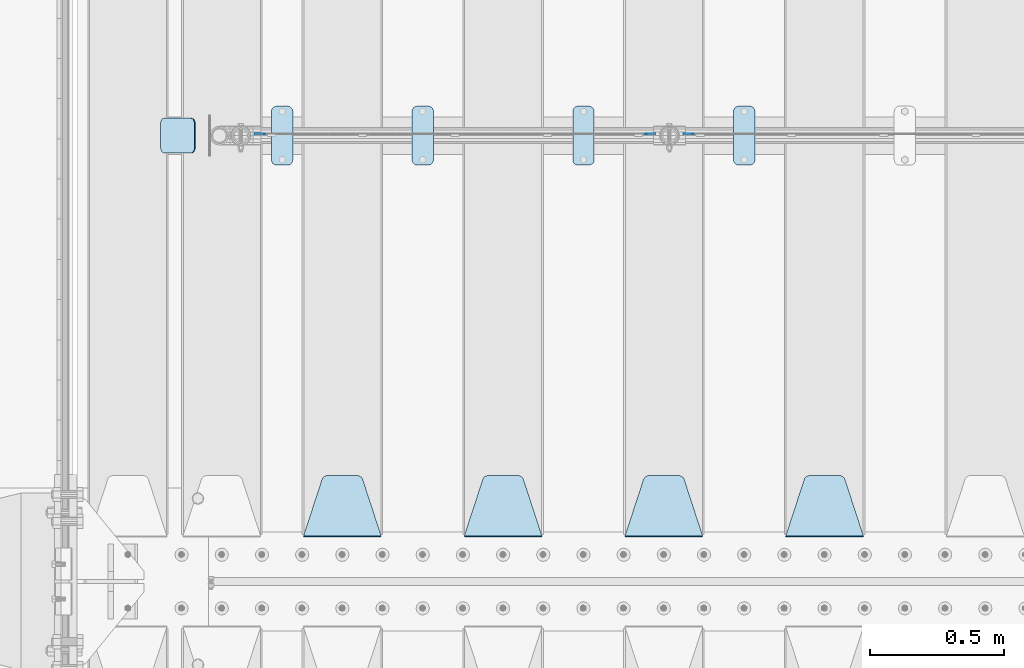
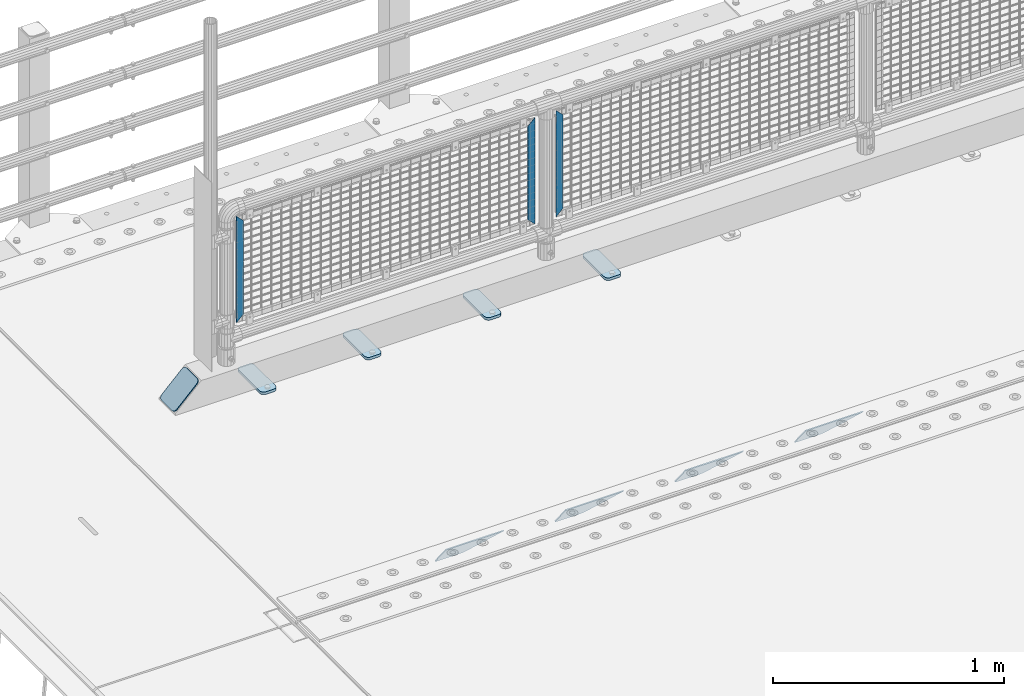
# One storey, part 170 of 208: 12 plates.
"""IFC2X3 building model written with IfcOpenShell, lengths in millimetres."""

from ifc_helpers import new_model, si_unit, frame, origin_with_axes, place, context, subcontext, project, spatial, faceted_brep, material, type_object, element, save


model = new_model("IFC2X3")

# Units and contexts
model_context = context("Model", 3, precision=1e-05, world=origin_with_axes())
body_context = subcontext(model_context, "Body", "Model", "MODEL_VIEW")
ifc_project = project(units=[si_unit("LENGTHUNIT", "METRE", prefix="MILLI"), si_unit("AREAUNIT", "SQUARE_METRE"), si_unit("VOLUMEUNIT", "CUBIC_METRE"), si_unit("MASSUNIT", "GRAM", prefix="KILO"), si_unit("TIMEUNIT", "SECOND"), si_unit("PLANEANGLEUNIT", "RADIAN"), si_unit("SOLIDANGLEUNIT", "STERADIAN"), si_unit("THERMODYNAMICTEMPERATUREUNIT", "DEGREE_CELSIUS"), si_unit("LUMINOUSINTENSITYUNIT", "LUMEN")], contexts=[model_context])

# Site, building, storey
site_placement = place(None, origin_with_axes())
site = spatial("IfcSite", under=ifc_project, at=site_placement, CompositionType="ELEMENT")
building_placement = place(site_placement, origin_with_axes())
building = spatial("IfcBuilding", under=site, at=building_placement, Name="Standard", CompositionType="ELEMENT")
storey_placement = place(building_placement, origin_with_axes())
storey = spatial("IfcBuildingStorey", under=building, at=storey_placement, Name="Undefined", CompositionType="ELEMENT", Elevation=0.0)

# Plates
ifc_material_1 = material(Name="STEEL/S355J2")
plate_type_1 = type_object("IfcPlateType", PredefinedType="NOTDEFINED")
plate_1_placement = place(storey_placement, frame((-39990.0, 4774.5, 21.0199999999977), z_axis=(1.0, 0.0, 0.0), x_axis=(0.0, -1.0, 0.0)))
element("IfcPlate", 1, at=plate_1_placement, inside=storey, type_object=plate_type_1, material=ifc_material_1, context=body_context, shape_type="Brep", body=[
    faceted_brep([(0.0, -7.0, 20.0), (0.0, -7.0, 60.0), (0.0, 7.0, 60.0), (0.0, 7.0, 20.0), (0.384294391935327, -7.0, 63.9018064403208), (0.384294391935327, 7.0, 63.9018064403208), (1.52240934977453, -7.0, 67.6536686473009), (1.52240934977453, 7.0, 67.6536686473009), (3.37060775394912, -7.0, 71.1114046603907), (3.37060775394912, 7.0, 71.1114046603907), (5.85786437626939, -7.0, 74.1421356237297), (5.85786437626939, 7.0, 74.1421356237297), (8.8885953396084, -7.0, 76.62939224605), (8.8885953396084, 7.0, 76.62939224605), (12.3463313526981, -7.0, 78.4775906502255), (12.3463313526981, 7.0, 78.4775906502255), (16.0981935596774, -7.0, 79.6157056080629), (16.0981935596774, 7.0, 79.6157056080629), (20.0, -7.0, 80.0), (20.0, 7.0, 80.0), (200.0, -7.0, 80.0), (200.0, 7.0, 80.0), (203.901806440323, -7.0, 79.6157056080629), (203.901806440323, 7.0, 79.6157056080629), (207.653668647302, -7.0, 78.4775906502255), (207.653668647302, 7.0, 78.4775906502255), (211.111404660393, -7.0, 76.62939224605), (211.111404660393, 7.0, 76.62939224605), (214.142135623731, -7.0, 74.1421356237297), (214.142135623731, 7.0, 74.1421356237297), (216.629392246051, -7.0, 71.1114046603907), (216.629392246051, 7.0, 71.1114046603907), (218.477590650225, -7.0, 67.6536686473009), (218.477590650225, 7.0, 67.6536686473009), (219.615705608065, -7.0, 63.9018064403208), (219.615705608065, 7.0, 63.9018064403208), (220.0, -7.0, 60.0), (220.0, 7.0, 60.0), (220.0, -7.0, 20.0), (220.0, 7.0, 20.0), (219.615705608065, -7.0, 16.0981935596792), (219.615705608065, 7.0, 16.0981935596792), (218.477590650225, -7.0, 12.3463313526991), (218.477590650225, 7.0, 12.3463313526991), (216.629392246051, -7.0, 8.88859533960931), (216.629392246051, 7.0, 8.88859533960931), (214.142135623731, -7.0, 5.8578643762703), (214.142135623731, 7.0, 5.8578643762703), (211.111404660393, -7.0, 3.37060775395003), (211.111404660393, 7.0, 3.37060775395003), (207.653668647302, -7.0, 1.52240934977453), (207.653668647302, 7.0, 1.52240934977453), (203.901806440323, -7.0, 0.384294391937146), (203.901806440323, 7.0, 0.384294391937146), (200.0, -7.0, 0.0), (200.0, 7.0, 0.0), (20.0, -7.0, 0.0), (20.0, 7.0, 0.0), (16.0981935596774, -7.0, 0.384294391937146), (16.0981935596774, 7.0, 0.384294391937146), (12.3463313526981, -7.0, 1.52240934977453), (12.3463313526981, 7.0, 1.52240934977453), (8.8885953396084, -7.0, 3.37060775395003), (8.8885953396084, 7.0, 3.37060775395003), (5.85786437626939, -7.0, 5.8578643762703), (5.85786437626939, 7.0, 5.8578643762703), (3.37060775394912, -7.0, 8.88859533960931), (3.37060775394912, 7.0, 8.88859533960931), (1.52240934977453, -7.0, 12.3463313526991), (1.52240934977453, 7.0, 12.3463313526991), (0.384294391935327, -7.0, 16.0981935596792), (0.384294391935327, 7.0, 16.0981935596792)], [[[0, 1, 2, 3]], [[1, 4, 5, 2]], [[4, 6, 7, 5]], [[6, 8, 9, 7]], [[8, 10, 11, 9]], [[10, 12, 13, 11]], [[12, 14, 15, 13]], [[14, 16, 17, 15]], [[16, 18, 19, 17]], [[18, 20, 21, 19]], [[20, 22, 23, 21]], [[22, 24, 25, 23]], [[24, 26, 27, 25]], [[26, 28, 29, 27]], [[28, 30, 31, 29]], [[30, 32, 33, 31]], [[32, 34, 35, 33]], [[34, 36, 37, 35]], [[36, 38, 39, 37]], [[38, 40, 41, 39]], [[40, 42, 43, 41]], [[42, 44, 45, 43]], [[44, 46, 47, 45]], [[46, 48, 49, 47]], [[48, 50, 51, 49]], [[50, 52, 53, 51]], [[52, 54, 55, 53]], [[54, 56, 57, 55]], [[56, 58, 59, 57]], [[58, 60, 61, 59]], [[60, 62, 63, 61]], [[62, 64, 65, 63]], [[64, 66, 67, 65]], [[66, 68, 69, 67]], [[68, 70, 71, 69]], [[70, 0, 3, 71]], [[5, 7, 9, 11, 13, 15, 17, 19, 21, 23, 25, 27, 29, 31, 33, 35, 37, 39, 41, 43, 45, 47, 49, 51, 53, 55, 57, 59, 61, 63, 65, 67, 69, 71, 3, 2]], [[70, 68, 66, 64, 62, 60, 58, 56, 54, 52, 50, 48, 46, 44, 42, 40, 38, 36, 34, 32, 30, 28, 26, 24, 22, 20, 18, 16, 14, 12, 10, 8, 6, 4, 1, 0]]]),
])
plate_2_placement = place(storey_placement, frame((-40590.0, 4774.5, 21.0199999999977), z_axis=(1.0, 0.0, 0.0), x_axis=(0.0, -1.0, 0.0)))
element("IfcPlate", 2, at=plate_2_placement, inside=storey, type_object=plate_type_1, material=ifc_material_1, context=body_context, shape_type="Brep", body=[
    faceted_brep([(0.0, -7.0, 20.0), (0.0, -7.0, 60.0), (0.0, 7.0, 60.0), (0.0, 7.0, 20.0), (0.384294391935327, -7.0, 63.9018064403208), (0.384294391935327, 7.0, 63.9018064403208), (1.52240934977453, -7.0, 67.6536686473009), (1.52240934977453, 7.0, 67.6536686473009), (3.37060775394912, -7.0, 71.1114046603907), (3.37060775394912, 7.0, 71.1114046603907), (5.85786437626939, -7.0, 74.1421356237297), (5.85786437626939, 7.0, 74.1421356237297), (8.8885953396084, -7.0, 76.62939224605), (8.8885953396084, 7.0, 76.62939224605), (12.3463313526981, -7.0, 78.4775906502255), (12.3463313526981, 7.0, 78.4775906502255), (16.0981935596774, -7.0, 79.6157056080629), (16.0981935596774, 7.0, 79.6157056080629), (20.0, -7.0, 80.0), (20.0, 7.0, 80.0), (200.0, -7.0, 80.0), (200.0, 7.0, 80.0), (203.901806440323, -7.0, 79.6157056080629), (203.901806440323, 7.0, 79.6157056080629), (207.653668647302, -7.0, 78.4775906502255), (207.653668647302, 7.0, 78.4775906502255), (211.111404660393, -7.0, 76.62939224605), (211.111404660393, 7.0, 76.62939224605), (214.142135623731, -7.0, 74.1421356237297), (214.142135623731, 7.0, 74.1421356237297), (216.629392246051, -7.0, 71.1114046603907), (216.629392246051, 7.0, 71.1114046603907), (218.477590650225, -7.0, 67.6536686473009), (218.477590650225, 7.0, 67.6536686473009), (219.615705608065, -7.0, 63.9018064403208), (219.615705608065, 7.0, 63.9018064403208), (220.0, -7.0, 60.0), (220.0, 7.0, 60.0), (220.0, -7.0, 20.0), (220.0, 7.0, 20.0), (219.615705608065, -7.0, 16.0981935596792), (219.615705608065, 7.0, 16.0981935596792), (218.477590650225, -7.0, 12.3463313526991), (218.477590650225, 7.0, 12.3463313526991), (216.629392246051, -7.0, 8.88859533960931), (216.629392246051, 7.0, 8.88859533960931), (214.142135623731, -7.0, 5.8578643762703), (214.142135623731, 7.0, 5.8578643762703), (211.111404660393, -7.0, 3.37060775395003), (211.111404660393, 7.0, 3.37060775395003), (207.653668647302, -7.0, 1.52240934977453), (207.653668647302, 7.0, 1.52240934977453), (203.901806440323, -7.0, 0.384294391937146), (203.901806440323, 7.0, 0.384294391937146), (200.0, -7.0, 0.0), (200.0, 7.0, 0.0), (20.0, -7.0, 0.0), (20.0, 7.0, 0.0), (16.0981935596774, -7.0, 0.384294391937146), (16.0981935596774, 7.0, 0.384294391937146), (12.3463313526981, -7.0, 1.52240934977453), (12.3463313526981, 7.0, 1.52240934977453), (8.8885953396084, -7.0, 3.37060775395003), (8.8885953396084, 7.0, 3.37060775395003), (5.85786437626939, -7.0, 5.8578643762703), (5.85786437626939, 7.0, 5.8578643762703), (3.37060775394912, -7.0, 8.88859533960931), (3.37060775394912, 7.0, 8.88859533960931), (1.52240934977453, -7.0, 12.3463313526991), (1.52240934977453, 7.0, 12.3463313526991), (0.384294391935327, -7.0, 16.0981935596792), (0.384294391935327, 7.0, 16.0981935596792)], [[[0, 1, 2, 3]], [[1, 4, 5, 2]], [[4, 6, 7, 5]], [[6, 8, 9, 7]], [[8, 10, 11, 9]], [[10, 12, 13, 11]], [[12, 14, 15, 13]], [[14, 16, 17, 15]], [[16, 18, 19, 17]], [[18, 20, 21, 19]], [[20, 22, 23, 21]], [[22, 24, 25, 23]], [[24, 26, 27, 25]], [[26, 28, 29, 27]], [[28, 30, 31, 29]], [[30, 32, 33, 31]], [[32, 34, 35, 33]], [[34, 36, 37, 35]], [[36, 38, 39, 37]], [[38, 40, 41, 39]], [[40, 42, 43, 41]], [[42, 44, 45, 43]], [[44, 46, 47, 45]], [[46, 48, 49, 47]], [[48, 50, 51, 49]], [[50, 52, 53, 51]], [[52, 54, 55, 53]], [[54, 56, 57, 55]], [[56, 58, 59, 57]], [[58, 60, 61, 59]], [[60, 62, 63, 61]], [[62, 64, 65, 63]], [[64, 66, 67, 65]], [[66, 68, 69, 67]], [[68, 70, 71, 69]], [[70, 0, 3, 71]], [[5, 7, 9, 11, 13, 15, 17, 19, 21, 23, 25, 27, 29, 31, 33, 35, 37, 39, 41, 43, 45, 47, 49, 51, 53, 55, 57, 59, 61, 63, 65, 67, 69, 71, 3, 2]], [[70, 68, 66, 64, 62, 60, 58, 56, 54, 52, 50, 48, 46, 44, 42, 40, 38, 36, 34, 32, 30, 28, 26, 24, 22, 20, 18, 16, 14, 12, 10, 8, 6, 4, 1, 0]]]),
])
plate_3_placement = place(storey_placement, frame((-41190.0, 4774.5, 21.0199999999977), z_axis=(1.0, 0.0, 0.0), x_axis=(0.0, -1.0, 0.0)))
element("IfcPlate", 3, at=plate_3_placement, inside=storey, type_object=plate_type_1, material=ifc_material_1, context=body_context, shape_type="Brep", body=[
    faceted_brep([(0.0, -7.0, 20.0), (0.0, -7.0, 60.0), (0.0, 7.0, 60.0), (0.0, 7.0, 20.0), (0.384294391935327, -7.0, 63.9018064403208), (0.384294391935327, 7.0, 63.9018064403208), (1.52240934977453, -7.0, 67.6536686473009), (1.52240934977453, 7.0, 67.6536686473009), (3.37060775394912, -7.0, 71.1114046603907), (3.37060775394912, 7.0, 71.1114046603907), (5.85786437626939, -7.0, 74.1421356237297), (5.85786437626939, 7.0, 74.1421356237297), (8.8885953396084, -7.0, 76.62939224605), (8.8885953396084, 7.0, 76.62939224605), (12.3463313526981, -7.0, 78.4775906502255), (12.3463313526981, 7.0, 78.4775906502255), (16.0981935596774, -7.0, 79.6157056080629), (16.0981935596774, 7.0, 79.6157056080629), (20.0, -7.0, 80.0), (20.0, 7.0, 80.0), (200.0, -7.0, 80.0), (200.0, 7.0, 80.0), (203.901806440323, -7.0, 79.6157056080629), (203.901806440323, 7.0, 79.6157056080629), (207.653668647302, -7.0, 78.4775906502255), (207.653668647302, 7.0, 78.4775906502255), (211.111404660393, -7.0, 76.62939224605), (211.111404660393, 7.0, 76.62939224605), (214.142135623731, -7.0, 74.1421356237297), (214.142135623731, 7.0, 74.1421356237297), (216.629392246051, -7.0, 71.1114046603907), (216.629392246051, 7.0, 71.1114046603907), (218.477590650225, -7.0, 67.6536686473009), (218.477590650225, 7.0, 67.6536686473009), (219.615705608065, -7.0, 63.9018064403208), (219.615705608065, 7.0, 63.9018064403208), (220.0, -7.0, 60.0), (220.0, 7.0, 60.0), (220.0, -7.0, 20.0), (220.0, 7.0, 20.0), (219.615705608065, -7.0, 16.0981935596792), (219.615705608065, 7.0, 16.0981935596792), (218.477590650225, -7.0, 12.3463313526991), (218.477590650225, 7.0, 12.3463313526991), (216.629392246051, -7.0, 8.88859533960931), (216.629392246051, 7.0, 8.88859533960931), (214.142135623731, -7.0, 5.8578643762703), (214.142135623731, 7.0, 5.8578643762703), (211.111404660393, -7.0, 3.37060775395003), (211.111404660393, 7.0, 3.37060775395003), (207.653668647302, -7.0, 1.52240934977453), (207.653668647302, 7.0, 1.52240934977453), (203.901806440323, -7.0, 0.384294391937146), (203.901806440323, 7.0, 0.384294391937146), (200.0, -7.0, 0.0), (200.0, 7.0, 0.0), (20.0, -7.0, 0.0), (20.0, 7.0, 0.0), (16.0981935596774, -7.0, 0.384294391937146), (16.0981935596774, 7.0, 0.384294391937146), (12.3463313526981, -7.0, 1.52240934977453), (12.3463313526981, 7.0, 1.52240934977453), (8.8885953396084, -7.0, 3.37060775395003), (8.8885953396084, 7.0, 3.37060775395003), (5.85786437626939, -7.0, 5.8578643762703), (5.85786437626939, 7.0, 5.8578643762703), (3.37060775394912, -7.0, 8.88859533960931), (3.37060775394912, 7.0, 8.88859533960931), (1.52240934977453, -7.0, 12.3463313526991), (1.52240934977453, 7.0, 12.3463313526991), (0.384294391935327, -7.0, 16.0981935596792), (0.384294391935327, 7.0, 16.0981935596792)], [[[0, 1, 2, 3]], [[1, 4, 5, 2]], [[4, 6, 7, 5]], [[6, 8, 9, 7]], [[8, 10, 11, 9]], [[10, 12, 13, 11]], [[12, 14, 15, 13]], [[14, 16, 17, 15]], [[16, 18, 19, 17]], [[18, 20, 21, 19]], [[20, 22, 23, 21]], [[22, 24, 25, 23]], [[24, 26, 27, 25]], [[26, 28, 29, 27]], [[28, 30, 31, 29]], [[30, 32, 33, 31]], [[32, 34, 35, 33]], [[34, 36, 37, 35]], [[36, 38, 39, 37]], [[38, 40, 41, 39]], [[40, 42, 43, 41]], [[42, 44, 45, 43]], [[44, 46, 47, 45]], [[46, 48, 49, 47]], [[48, 50, 51, 49]], [[50, 52, 53, 51]], [[52, 54, 55, 53]], [[54, 56, 57, 55]], [[56, 58, 59, 57]], [[58, 60, 61, 59]], [[60, 62, 63, 61]], [[62, 64, 65, 63]], [[64, 66, 67, 65]], [[66, 68, 69, 67]], [[68, 70, 71, 69]], [[70, 0, 3, 71]], [[5, 7, 9, 11, 13, 15, 17, 19, 21, 23, 25, 27, 29, 31, 33, 35, 37, 39, 41, 43, 45, 47, 49, 51, 53, 55, 57, 59, 61, 63, 65, 67, 69, 71, 3, 2]], [[70, 68, 66, 64, 62, 60, 58, 56, 54, 52, 50, 48, 46, 44, 42, 40, 38, 36, 34, 32, 30, 28, 26, 24, 22, 20, 18, 16, 14, 12, 10, 8, 6, 4, 1, 0]]]),
])
plate_4_placement = place(storey_placement, frame((-41715.0, 4774.5, 21.0199999999977), z_axis=(1.0, 0.0, 0.0), x_axis=(0.0, -1.0, 0.0)))
element("IfcPlate", 4, at=plate_4_placement, inside=storey, type_object=plate_type_1, material=ifc_material_1, context=body_context, shape_type="Brep", body=[
    faceted_brep([(0.0, -7.0, 20.0), (0.0, -7.0, 60.0), (0.0, 7.0, 60.0), (0.0, 7.0, 20.0), (0.384294391935327, -7.0, 63.9018064403208), (0.384294391935327, 7.0, 63.9018064403208), (1.52240934977453, -7.0, 67.6536686473009), (1.52240934977453, 7.0, 67.6536686473009), (3.37060775394912, -7.0, 71.1114046603907), (3.37060775394912, 7.0, 71.1114046603907), (5.85786437626939, -7.0, 74.1421356237297), (5.85786437626939, 7.0, 74.1421356237297), (8.8885953396084, -7.0, 76.62939224605), (8.8885953396084, 7.0, 76.62939224605), (12.3463313526981, -7.0, 78.4775906502255), (12.3463313526981, 7.0, 78.4775906502255), (16.0981935596774, -7.0, 79.6157056080629), (16.0981935596774, 7.0, 79.6157056080629), (20.0, -7.0, 80.0), (20.0, 7.0, 80.0), (200.0, -7.0, 80.0), (200.0, 7.0, 80.0), (203.901806440323, -7.0, 79.6157056080629), (203.901806440323, 7.0, 79.6157056080629), (207.653668647302, -7.0, 78.4775906502255), (207.653668647302, 7.0, 78.4775906502255), (211.111404660393, -7.0, 76.62939224605), (211.111404660393, 7.0, 76.62939224605), (214.142135623731, -7.0, 74.1421356237297), (214.142135623731, 7.0, 74.1421356237297), (216.629392246051, -7.0, 71.1114046603907), (216.629392246051, 7.0, 71.1114046603907), (218.477590650225, -7.0, 67.6536686473009), (218.477590650225, 7.0, 67.6536686473009), (219.615705608065, -7.0, 63.9018064403208), (219.615705608065, 7.0, 63.9018064403208), (220.0, -7.0, 60.0), (220.0, 7.0, 60.0), (220.0, -7.0, 20.0), (220.0, 7.0, 20.0), (219.615705608065, -7.0, 16.0981935596792), (219.615705608065, 7.0, 16.0981935596792), (218.477590650225, -7.0, 12.3463313526991), (218.477590650225, 7.0, 12.3463313526991), (216.629392246051, -7.0, 8.88859533960931), (216.629392246051, 7.0, 8.88859533960931), (214.142135623731, -7.0, 5.8578643762703), (214.142135623731, 7.0, 5.8578643762703), (211.111404660393, -7.0, 3.37060775395003), (211.111404660393, 7.0, 3.37060775395003), (207.653668647302, -7.0, 1.52240934977453), (207.653668647302, 7.0, 1.52240934977453), (203.901806440323, -7.0, 0.384294391937146), (203.901806440323, 7.0, 0.384294391937146), (200.0, -7.0, 0.0), (200.0, 7.0, 0.0), (20.0, -7.0, 0.0), (20.0, 7.0, 0.0), (16.0981935596774, -7.0, 0.384294391937146), (16.0981935596774, 7.0, 0.384294391937146), (12.3463313526981, -7.0, 1.52240934977453), (12.3463313526981, 7.0, 1.52240934977453), (8.8885953396084, -7.0, 3.37060775395003), (8.8885953396084, 7.0, 3.37060775395003), (5.85786437626939, -7.0, 5.8578643762703), (5.85786437626939, 7.0, 5.8578643762703), (3.37060775394912, -7.0, 8.88859533960931), (3.37060775394912, 7.0, 8.88859533960931), (1.52240934977453, -7.0, 12.3463313526991), (1.52240934977453, 7.0, 12.3463313526991), (0.384294391935327, -7.0, 16.0981935596792), (0.384294391935327, 7.0, 16.0981935596792)], [[[0, 1, 2, 3]], [[1, 4, 5, 2]], [[4, 6, 7, 5]], [[6, 8, 9, 7]], [[8, 10, 11, 9]], [[10, 12, 13, 11]], [[12, 14, 15, 13]], [[14, 16, 17, 15]], [[16, 18, 19, 17]], [[18, 20, 21, 19]], [[20, 22, 23, 21]], [[22, 24, 25, 23]], [[24, 26, 27, 25]], [[26, 28, 29, 27]], [[28, 30, 31, 29]], [[30, 32, 33, 31]], [[32, 34, 35, 33]], [[34, 36, 37, 35]], [[36, 38, 39, 37]], [[38, 40, 41, 39]], [[40, 42, 43, 41]], [[42, 44, 45, 43]], [[44, 46, 47, 45]], [[46, 48, 49, 47]], [[48, 50, 51, 49]], [[50, 52, 53, 51]], [[52, 54, 55, 53]], [[54, 56, 57, 55]], [[56, 58, 59, 57]], [[58, 60, 61, 59]], [[60, 62, 63, 61]], [[62, 64, 65, 63]], [[64, 66, 67, 65]], [[66, 68, 69, 67]], [[68, 70, 71, 69]], [[70, 0, 3, 71]], [[5, 7, 9, 11, 13, 15, 17, 19, 21, 23, 25, 27, 29, 31, 33, 35, 37, 39, 41, 43, 45, 47, 49, 51, 53, 55, 57, 59, 61, 63, 65, 67, 69, 71, 3, 2]], [[70, 68, 66, 64, 62, 60, 58, 56, 54, 52, 50, 48, 46, 44, 42, 40, 38, 36, 34, 32, 30, 28, 26, 24, 22, 20, 18, 16, 14, 12, 10, 8, 6, 4, 1, 0]]]),
])
ifc_material_2 = material(Name="STEEL/S355N")
plate_type_2 = type_object("IfcPlateType", PredefinedType="NOTDEFINED")
plate_5_placement = place(storey_placement, frame((-39505.0, 3168.23223304702, -1.76776695296758), z_axis=(0.0, 0.707106781186547, -0.707106781186548), x_axis=(-1.0, 0.0, 0.0)))
element("IfcPlate", 5, at=plate_5_placement, inside=storey, type_object=plate_type_2, material=ifc_material_2, context=body_context, shape_type="Brep", body=[
    faceted_brep([(0.0, -2.5, 0.0), (69.345504679477, -2.5, 300.17173142483), (69.345504679477, 2.5, 300.17173142483), (0.0, 2.5, 0.0), (70.9274061199576, -2.5, 304.897442415399), (70.9274061199576, 2.5, 304.8974424154), (73.3818627772307, -2.5, 309.234538108527), (73.3818627772307, 2.5, 309.234538108527), (76.6187032999551, -2.5, 313.023683126103), (76.6187032999551, 2.5, 313.023683126103), (80.5190132704993, -2.5, 316.125672595371), (80.5190132704993, 2.5, 316.125672595371), (84.9395038596849, -2.5, 318.426546230476), (84.9395038596849, 2.50000000000091, 318.426546230476), (89.7177759439219, -2.5, 319.841774983275), (89.7177759439219, 2.50000000000091, 319.841774983275), (94.678286292652, -2.49999999999909, 320.319366455078), (94.678286292652, 2.5, 320.319366455078), (195.321713707348, -2.49999999999909, 320.319366455078), (195.321713707348, 2.5, 320.319366455078), (200.282224056078, -2.5, 319.841774983275), (200.282224056078, 2.5, 319.841774983274), (205.060496140315, -2.5, 318.426546230475), (205.060496140315, 2.5, 318.426546230475), (209.480986729501, -2.5, 316.125672595371), (209.480986729501, 2.50000000000091, 316.125672595371), (213.381296700045, -2.5, 313.023683126102), (213.381296700045, 2.5, 313.023683126102), (216.618137222769, -2.5, 309.234538108526), (216.618137222769, 2.5, 309.234538108527), (219.072593880042, -2.5, 304.897442415399), (219.072593880042, 2.5, 304.897442415399), (220.654495320523, -2.5, 300.17173142483), (220.654495320523, 2.5, 300.17173142483), (290.0, -2.5, 0.0), (290.0, 2.5, 0.0)], [[[0, 1, 2, 3]], [[1, 4, 5, 2]], [[4, 6, 7, 5]], [[6, 8, 9, 7]], [[8, 10, 11, 9]], [[10, 12, 13, 11]], [[12, 14, 15, 13]], [[14, 16, 17, 15]], [[16, 18, 19, 17]], [[18, 20, 21, 19]], [[20, 22, 23, 21]], [[22, 24, 25, 23]], [[24, 26, 27, 25]], [[26, 28, 29, 27]], [[28, 30, 31, 29]], [[30, 32, 33, 31]], [[32, 34, 35, 33]], [[34, 0, 3, 35]], [[5, 7, 9, 11, 13, 15, 17, 19, 21, 23, 25, 27, 29, 31, 33, 35, 3, 2]], [[34, 32, 30, 28, 26, 24, 22, 20, 18, 16, 14, 12, 10, 8, 6, 4, 1, 0]]]),
])
plate_6_placement = place(storey_placement, frame((-40105.0, 3168.23223304702, -1.76776695296758), z_axis=(0.0, 0.707106781186547, -0.707106781186548), x_axis=(-1.0, 0.0, 0.0)))
element("IfcPlate", 6, at=plate_6_placement, inside=storey, type_object=plate_type_2, material=ifc_material_2, context=body_context, shape_type="Brep", body=[
    faceted_brep([(0.0, -2.5, 0.0), (69.345504679477, -2.5, 300.17173142483), (69.345504679477, 2.5, 300.17173142483), (0.0, 2.5, 0.0), (70.9274061199576, -2.5, 304.897442415399), (70.9274061199576, 2.5, 304.8974424154), (73.3818627772307, -2.5, 309.234538108527), (73.3818627772307, 2.5, 309.234538108527), (76.6187032999551, -2.5, 313.023683126103), (76.6187032999551, 2.5, 313.023683126103), (80.5190132704993, -2.5, 316.125672595371), (80.5190132704993, 2.5, 316.125672595371), (84.9395038596849, -2.5, 318.426546230476), (84.9395038596849, 2.50000000000091, 318.426546230476), (89.7177759439219, -2.5, 319.841774983275), (89.7177759439219, 2.50000000000091, 319.841774983275), (94.678286292652, -2.49999999999909, 320.319366455078), (94.678286292652, 2.5, 320.319366455078), (195.321713707348, -2.49999999999909, 320.319366455078), (195.321713707348, 2.5, 320.319366455078), (200.282224056078, -2.5, 319.841774983275), (200.282224056078, 2.5, 319.841774983274), (205.060496140315, -2.5, 318.426546230475), (205.060496140315, 2.5, 318.426546230475), (209.480986729501, -2.5, 316.125672595371), (209.480986729501, 2.50000000000091, 316.125672595371), (213.381296700045, -2.5, 313.023683126102), (213.381296700045, 2.5, 313.023683126102), (216.618137222769, -2.5, 309.234538108526), (216.618137222769, 2.5, 309.234538108527), (219.072593880042, -2.5, 304.897442415399), (219.072593880042, 2.5, 304.897442415399), (220.654495320523, -2.5, 300.17173142483), (220.654495320523, 2.5, 300.17173142483), (290.0, -2.5, 0.0), (290.0, 2.5, 0.0)], [[[0, 1, 2, 3]], [[1, 4, 5, 2]], [[4, 6, 7, 5]], [[6, 8, 9, 7]], [[8, 10, 11, 9]], [[10, 12, 13, 11]], [[12, 14, 15, 13]], [[14, 16, 17, 15]], [[16, 18, 19, 17]], [[18, 20, 21, 19]], [[20, 22, 23, 21]], [[22, 24, 25, 23]], [[24, 26, 27, 25]], [[26, 28, 29, 27]], [[28, 30, 31, 29]], [[30, 32, 33, 31]], [[32, 34, 35, 33]], [[34, 0, 3, 35]], [[5, 7, 9, 11, 13, 15, 17, 19, 21, 23, 25, 27, 29, 31, 33, 35, 3, 2]], [[34, 32, 30, 28, 26, 24, 22, 20, 18, 16, 14, 12, 10, 8, 6, 4, 1, 0]]]),
])
plate_7_placement = place(storey_placement, frame((-40705.0, 3168.23223304702, -1.76776695296758), z_axis=(0.0, 0.707106781186547, -0.707106781186548), x_axis=(-1.0, 0.0, 0.0)))
element("IfcPlate", 7, at=plate_7_placement, inside=storey, type_object=plate_type_2, material=ifc_material_2, context=body_context, shape_type="Brep", body=[
    faceted_brep([(0.0, -2.5, 0.0), (69.345504679477, -2.5, 300.17173142483), (69.345504679477, 2.5, 300.17173142483), (0.0, 2.5, 0.0), (70.9274061199576, -2.5, 304.897442415399), (70.9274061199576, 2.5, 304.8974424154), (73.3818627772307, -2.5, 309.234538108527), (73.3818627772307, 2.5, 309.234538108527), (76.6187032999551, -2.5, 313.023683126103), (76.6187032999551, 2.5, 313.023683126103), (80.5190132704993, -2.5, 316.125672595371), (80.5190132704993, 2.5, 316.125672595371), (84.9395038596849, -2.5, 318.426546230476), (84.9395038596849, 2.50000000000091, 318.426546230476), (89.7177759439219, -2.5, 319.841774983275), (89.7177759439219, 2.50000000000091, 319.841774983275), (94.678286292652, -2.49999999999909, 320.319366455078), (94.678286292652, 2.5, 320.319366455078), (195.321713707348, -2.49999999999909, 320.319366455078), (195.321713707348, 2.5, 320.319366455078), (200.282224056078, -2.5, 319.841774983275), (200.282224056078, 2.5, 319.841774983274), (205.060496140315, -2.5, 318.426546230475), (205.060496140315, 2.5, 318.426546230475), (209.480986729501, -2.5, 316.125672595371), (209.480986729501, 2.50000000000091, 316.125672595371), (213.381296700045, -2.5, 313.023683126102), (213.381296700045, 2.5, 313.023683126102), (216.618137222769, -2.5, 309.234538108526), (216.618137222769, 2.5, 309.234538108527), (219.072593880042, -2.5, 304.897442415399), (219.072593880042, 2.5, 304.897442415399), (220.654495320523, -2.5, 300.17173142483), (220.654495320523, 2.5, 300.17173142483), (290.0, -2.5, 0.0), (290.0, 2.5, 0.0)], [[[0, 1, 2, 3]], [[1, 4, 5, 2]], [[4, 6, 7, 5]], [[6, 8, 9, 7]], [[8, 10, 11, 9]], [[10, 12, 13, 11]], [[12, 14, 15, 13]], [[14, 16, 17, 15]], [[16, 18, 19, 17]], [[18, 20, 21, 19]], [[20, 22, 23, 21]], [[22, 24, 25, 23]], [[24, 26, 27, 25]], [[26, 28, 29, 27]], [[28, 30, 31, 29]], [[30, 32, 33, 31]], [[32, 34, 35, 33]], [[34, 0, 3, 35]], [[5, 7, 9, 11, 13, 15, 17, 19, 21, 23, 25, 27, 29, 31, 33, 35, 3, 2]], [[34, 32, 30, 28, 26, 24, 22, 20, 18, 16, 14, 12, 10, 8, 6, 4, 1, 0]]]),
])
plate_8_placement = place(storey_placement, frame((-41305.0, 3168.23223304702, -1.76776695296758), z_axis=(0.0, 0.707106781186547, -0.707106781186548), x_axis=(-1.0, 0.0, 0.0)))
element("IfcPlate", 8, at=plate_8_placement, inside=storey, type_object=plate_type_2, material=ifc_material_2, context=body_context, shape_type="Brep", body=[
    faceted_brep([(0.0, -2.5, 0.0), (69.345504679477, -2.5, 300.17173142483), (69.345504679477, 2.5, 300.17173142483), (0.0, 2.5, 0.0), (70.9274061199576, -2.5, 304.897442415399), (70.9274061199576, 2.5, 304.8974424154), (73.3818627772307, -2.5, 309.234538108527), (73.3818627772307, 2.5, 309.234538108527), (76.6187032999551, -2.5, 313.023683126103), (76.6187032999551, 2.5, 313.023683126103), (80.5190132704993, -2.5, 316.125672595371), (80.5190132704993, 2.5, 316.125672595371), (84.9395038596849, -2.5, 318.426546230476), (84.9395038596849, 2.50000000000091, 318.426546230476), (89.7177759439219, -2.5, 319.841774983275), (89.7177759439219, 2.50000000000091, 319.841774983275), (94.678286292652, -2.49999999999909, 320.319366455078), (94.678286292652, 2.5, 320.319366455078), (195.321713707348, -2.49999999999909, 320.319366455078), (195.321713707348, 2.5, 320.319366455078), (200.282224056078, -2.5, 319.841774983275), (200.282224056078, 2.5, 319.841774983274), (205.060496140315, -2.5, 318.426546230475), (205.060496140315, 2.5, 318.426546230475), (209.480986729501, -2.5, 316.125672595371), (209.480986729501, 2.50000000000091, 316.125672595371), (213.381296700045, -2.5, 313.023683126102), (213.381296700045, 2.5, 313.023683126102), (216.618137222769, -2.5, 309.234538108526), (216.618137222769, 2.5, 309.234538108527), (219.072593880042, -2.5, 304.897442415399), (219.072593880042, 2.5, 304.897442415399), (220.654495320523, -2.5, 300.17173142483), (220.654495320523, 2.5, 300.17173142483), (290.0, -2.5, 0.0), (290.0, 2.5, 0.0)], [[[0, 1, 2, 3]], [[1, 4, 5, 2]], [[4, 6, 7, 5]], [[6, 8, 9, 7]], [[8, 10, 11, 9]], [[10, 12, 13, 11]], [[12, 14, 15, 13]], [[14, 16, 17, 15]], [[16, 18, 19, 17]], [[18, 20, 21, 19]], [[20, 22, 23, 21]], [[22, 24, 25, 23]], [[24, 26, 27, 25]], [[26, 28, 29, 27]], [[28, 30, 31, 29]], [[30, 32, 33, 31]], [[32, 34, 35, 33]], [[34, 0, 3, 35]], [[5, 7, 9, 11, 13, 15, 17, 19, 21, 23, 25, 27, 29, 31, 33, 35, 3, 2]], [[34, 32, 30, 28, 26, 24, 22, 20, 18, 16, 14, 12, 10, 8, 6, 4, 1, 0]]]),
])
ifc_material_3 = material(Name="Misc_Undefined")
plate_type_3 = type_object("IfcPlateType", PredefinedType="NOTDEFINED")
for number, where, z_axis, x_axis in (
    (9, (-40140.490286459, 4670.5, 879.519963133601), (-0.707008801899319, 0.0, -0.707204746899291), (-0.70720474689929, 0.0, 0.707008801899319)),
    (10, (-41740.490286459, 4670.5, 879.519963133601), (-0.707008801899319, 0.0, -0.707204746899291), (-0.70720474689929, 0.0, 0.707008801899319)),
):
    element("IfcPlate", number, at=place(storey_placement, frame(where, z_axis=z_axis, x_axis=x_axis)), inside=storey, type_object=plate_type_3, material=ifc_material_3, context=body_context, shape_type="Brep", body=[
        faceted_brep([(0.0, -1.49999999999909, 3.63797880709171e-12), (-348.55218505859, -1.5, 348.655029296875), (-348.55218505859, 1.5, 348.655029296875), (0.0, 1.50000000000182, 3.63797880709171e-12), (-348.544891357418, -1.5, 398.152496337894), (-348.544891357418, 1.5, 398.152496337894), (49.5043945312536, -1.5, 7.6397554948926e-11), (49.5043945312536, 1.5, 7.6397554948926e-11)], [[[0, 1, 2, 3]], [[1, 4, 5, 2]], [[4, 6, 7, 5]], [[6, 0, 3, 7]], [[5, 7, 3, 2]], [[6, 4, 1, 0]]]),
    ])
plate_9_placement = place(storey_placement, frame((-40317.5003125164, 4670.5, 879.52), z_axis=(0.707103624179499, 0.0, -0.707109938179501), x_axis=(0.707109938179495, 0.0, 0.707103624179505)))
element("IfcPlate", 11, at=plate_9_placement, inside=storey, type_object=plate_type_3, material=ifc_material_3, context=body_context, shape_type="Brep", body=[
    faceted_brep([(0.0, -1.49999999999909, 3.63797880709171e-12), (-348.605163574219, -1.5, 348.602081298821), (-348.605163574219, 1.5, 348.602081298821), (0.0, 1.50000000000182, 3.63797880709171e-12), (-348.605163574219, -1.5, 398.099334716793), (-348.605163574219, 1.5, 398.099334716793), (49.4976959228516, -1.5, 6.91215973347425e-11), (49.4976959228516, 1.5, 6.91215973347425e-11)], [[[0, 1, 2, 3]], [[1, 4, 5, 2]], [[4, 6, 7, 5]], [[6, 0, 3, 7]], [[5, 7, 3, 2]], [[6, 4, 1, 0]]]),
])
plate_type_4 = type_object("IfcPlateType", PredefinedType="NOTDEFINED")
plate_10_placement = place(storey_placement, frame((-42000.192418479, 4729.5, 166.254400376559), z_axis=(-0.707410512925779, 0.0, -0.70680291892584), x_axis=(0.0, -1.0, 0.0)))
element("IfcPlate", 12, at=plate_10_placement, inside=storey, type_object=plate_type_4, material=ifc_material_1, context=body_context, shape_type="Brep", body=[
    faceted_brep([(0.0, -2.49999999999636, 20.0000000000036), (0.0, -2.49999999999636, 158.92665100098), (0.0, 2.5, 158.92665100098), (0.0, 2.50000000000364, 20.0000000000036), (0.384294391935327, -2.5, 162.828457441301), (0.384294391935327, 2.50000000000364, 162.828457441305), (1.52240934977453, -2.49999999999636, 166.580319648281), (1.52240934977453, 2.50000000000364, 166.580319648281), (3.37060775394912, -2.49999999999636, 170.038055661371), (3.37060775394912, 2.50000000000364, 170.038055661375), (5.85786437626939, -2.49999999999636, 173.06878662471), (5.85786437626939, 2.50000000000364, 173.06878662471), (8.8885953396084, -2.5, 175.55604324703), (8.8885953396084, 2.5, 175.55604324703), (12.3463313526981, -2.49999999999636, 177.404241651206), (12.3463313526981, 2.50000000000364, 177.404241651206), (16.0981935596774, -2.5, 178.542356609047), (16.0981935596774, 2.50000000000364, 178.542356609043), (20.0, -2.49999999999272, 178.92665100098), (20.0, 2.50000000000364, 178.92665100098), (110.0, -2.49999999999272, 178.92665100098), (110.0, 2.50000000000364, 178.92665100098), (113.901806440323, -2.5, 178.542356609047), (113.901806440323, 2.50000000000364, 178.542356609043), (117.653668647302, -2.49999999999636, 177.404241651206), (117.653668647302, 2.50000000000364, 177.404241651206), (121.111404660392, -2.5, 175.55604324703), (121.111404660392, 2.5, 175.55604324703), (124.142135623731, -2.49999999999636, 173.06878662471), (124.142135623731, 2.50000000000364, 173.06878662471), (126.629392246051, -2.49999999999636, 170.038055661371), (126.629392246051, 2.50000000000364, 170.038055661375), (128.477590650225, -2.49999999999636, 166.580319648281), (128.477590650225, 2.50000000000364, 166.580319648281), (129.615705608065, -2.5, 162.828457441301), (129.615705608065, 2.50000000000364, 162.828457441305), (130.0, -2.49999999999636, 158.92665100098), (130.0, 2.5, 158.92665100098), (130.0, -2.49999999999636, 20.0000000000036), (130.0, 2.50000000000364, 20.0000000000036), (129.615705608065, -2.49999999999636, 16.0981935596792), (129.615705608065, 2.50000000000364, 16.0981935596792), (128.477590650225, -2.49999999999636, 12.3463313526991), (128.477590650225, 2.50000000000364, 12.3463313526991), (126.629392246051, -2.49999999999636, 8.88859533961295), (126.629392246051, 2.5, 8.88859533960931), (124.142135623731, -2.49999999999636, 5.85786437627394), (124.142135623731, 2.5, 5.85786437627394), (121.111404660392, -2.49999999999636, 3.37060775395003), (121.111404660392, 2.50000000000364, 3.37060775395003), (117.653668647302, -2.5, 1.52240934977453), (117.653668647302, 2.50000000000364, 1.52240934977817), (113.901806440323, -2.49999999999636, 0.384294391937146), (113.901806440323, 2.50000000000364, 0.384294391937146), (110.0, -2.5, 7.27595761418343e-12), (110.0, 2.50000000000364, 3.63797880709171e-12), (20.0, -2.5, 7.27595761418343e-12), (20.0, 2.50000000000364, 3.63797880709171e-12), (16.0981935596774, -2.49999999999636, 0.384294391937146), (16.0981935596774, 2.50000000000364, 0.384294391937146), (12.3463313526981, -2.5, 1.52240934977453), (12.3463313526981, 2.50000000000364, 1.52240934977817), (8.8885953396084, -2.49999999999636, 3.37060775395003), (8.8885953396084, 2.50000000000364, 3.37060775395003), (5.85786437626939, -2.49999999999636, 5.85786437627394), (5.85786437626939, 2.5, 5.85786437627394), (3.37060775394912, -2.49999999999636, 8.88859533961295), (3.37060775394912, 2.5, 8.88859533960931), (1.52240934977453, -2.49999999999636, 12.3463313526991), (1.52240934977453, 2.50000000000364, 12.3463313526991), (0.384294391935327, -2.49999999999636, 16.0981935596792), (0.384294391935327, 2.50000000000364, 16.0981935596792)], [[[0, 1, 2, 3]], [[1, 4, 5, 2]], [[4, 6, 7, 5]], [[6, 8, 9, 7]], [[8, 10, 11, 9]], [[10, 12, 13, 11]], [[12, 14, 15, 13]], [[14, 16, 17, 15]], [[16, 18, 19, 17]], [[18, 20, 21, 19]], [[20, 22, 23, 21]], [[22, 24, 25, 23]], [[24, 26, 27, 25]], [[26, 28, 29, 27]], [[28, 30, 31, 29]], [[30, 32, 33, 31]], [[32, 34, 35, 33]], [[34, 36, 37, 35]], [[36, 38, 39, 37]], [[38, 40, 41, 39]], [[40, 42, 43, 41]], [[42, 44, 45, 43]], [[44, 46, 47, 45]], [[46, 48, 49, 47]], [[48, 50, 51, 49]], [[50, 52, 53, 51]], [[52, 54, 55, 53]], [[54, 56, 57, 55]], [[56, 58, 59, 57]], [[58, 60, 61, 59]], [[60, 62, 63, 61]], [[62, 64, 65, 63]], [[64, 66, 67, 65]], [[66, 68, 69, 67]], [[68, 70, 71, 69]], [[70, 0, 3, 71]], [[5, 7, 9, 11, 13, 15, 17, 19, 21, 23, 25, 27, 29, 31, 33, 35, 37, 39, 41, 43, 45, 47, 49, 51, 53, 55, 57, 59, 61, 63, 65, 67, 69, 71, 3, 2]], [[70, 68, 66, 64, 62, 60, 58, 56, 54, 52, 50, 48, 46, 44, 42, 40, 38, 36, 34, 32, 30, 28, 26, 24, 22, 20, 18, 16, 14, 12, 10, 8, 6, 4, 1, 0]]]),
])

save(model, "model.ifc")
